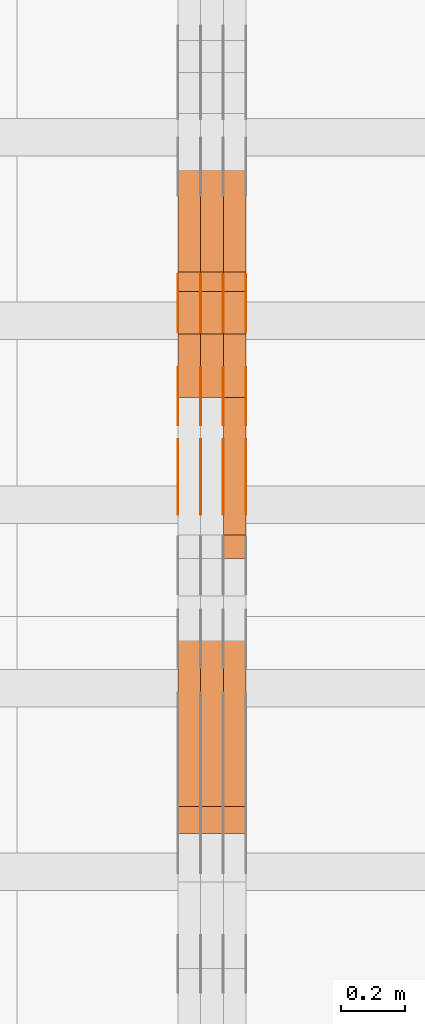
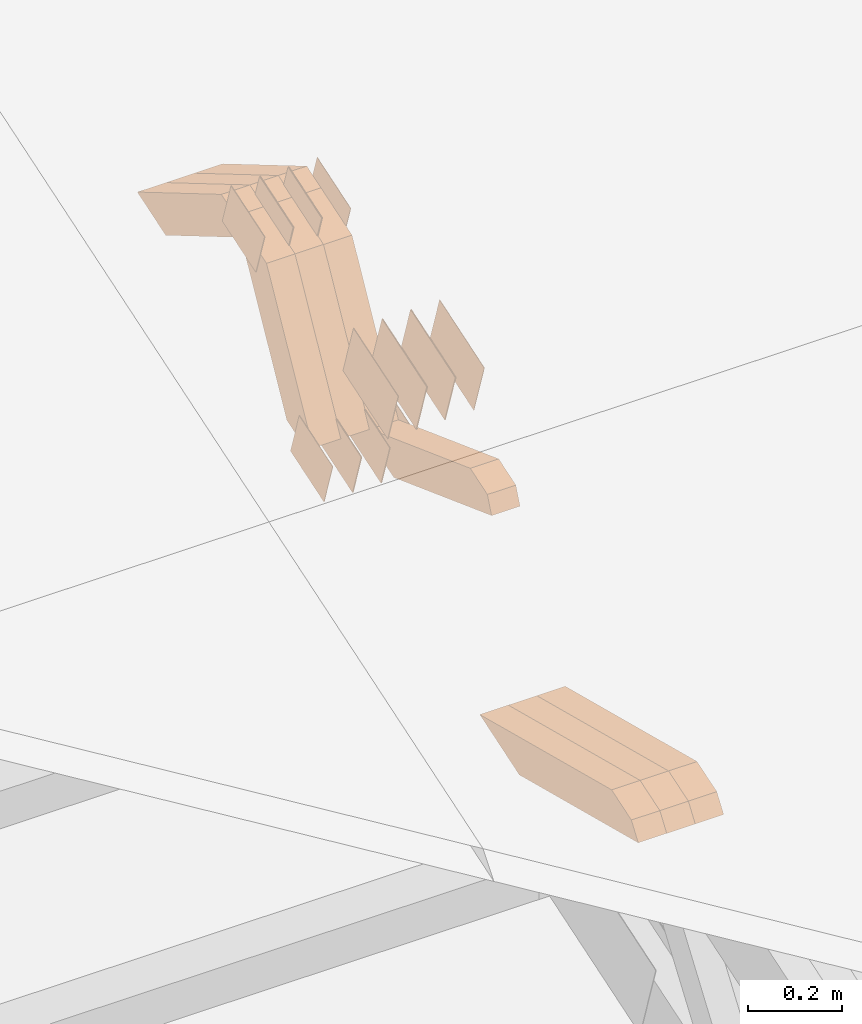
# One storey, part 140 of 385: 28 proxies.
"""IFC2X3 building model written with IfcOpenShell, lengths in millimetres."""

from ifc_helpers import new_model, entity, si_unit, converted_unit, derived_unit, direction, frame, origin, place, context, subcontext, project, spatial, polyline, outline, extrude, source, transform, mapped, material, type_object, type_shapes, element, save


model = new_model("IFC2X3")

# Units and contexts
model_context = context("Model", 3, precision=0.01, world=origin(), true_north=direction((6.12303176911189e-17, 1.0)))
body_context = subcontext(model_context, "Body", "Model", "MODEL_VIEW")
ifc_project = project(units=[si_unit("LENGTHUNIT", "METRE", prefix="MILLI"), si_unit("AREAUNIT", "SQUARE_METRE"), si_unit("VOLUMEUNIT", "CUBIC_METRE"), converted_unit("PLANEANGLEUNIT", "DEGREE", entity("IfcRatioMeasure", 0.0174532925199433), si_unit("PLANEANGLEUNIT", "RADIAN"), dimensions=[0, 0, 0, 0, 0, 0, 0]), si_unit("MASSUNIT", "GRAM", prefix="KILO"), derived_unit("MASSDENSITYUNIT", [(si_unit("MASSUNIT", "GRAM", prefix="KILO"), 1), (si_unit("LENGTHUNIT", "METRE"), -3)]), si_unit("TIMEUNIT", "SECOND"), si_unit("FREQUENCYUNIT", "HERTZ"), si_unit("THERMODYNAMICTEMPERATUREUNIT", "DEGREE_CELSIUS"), derived_unit("THERMALTRANSMITTANCEUNIT", [(si_unit("MASSUNIT", "GRAM", prefix="KILO"), 1), (si_unit("THERMODYNAMICTEMPERATUREUNIT", "KELVIN"), -1), (si_unit("TIMEUNIT", "SECOND"), -3)]), derived_unit("VOLUMETRICFLOWRATEUNIT", [(si_unit("LENGTHUNIT", "METRE"), 3), (si_unit("TIMEUNIT", "SECOND"), -1)]), si_unit("ELECTRICCURRENTUNIT", "AMPERE"), si_unit("ELECTRICVOLTAGEUNIT", "VOLT"), si_unit("POWERUNIT", "WATT"), si_unit("FORCEUNIT", "NEWTON", prefix="KILO"), si_unit("ILLUMINANCEUNIT", "LUX"), si_unit("LUMINOUSFLUXUNIT", "LUMEN"), si_unit("LUMINOUSINTENSITYUNIT", "CANDELA"), derived_unit("USERDEFINED", [(si_unit("MASSUNIT", "GRAM", prefix="KILO"), -1), (si_unit("LENGTHUNIT", "METRE"), -2), (si_unit("TIMEUNIT", "SECOND"), 3), (si_unit("LUMINOUSFLUXUNIT", "LUMEN"), 1)]), derived_unit("LINEARVELOCITYUNIT", [(si_unit("LENGTHUNIT", "METRE"), 1), (si_unit("TIMEUNIT", "SECOND"), -1)]), si_unit("PRESSUREUNIT", "PASCAL"), derived_unit("USERDEFINED", [(si_unit("LENGTHUNIT", "METRE"), -2), (si_unit("MASSUNIT", "GRAM", prefix="KILO"), 1), (si_unit("TIMEUNIT", "SECOND"), -2)])], contexts=[model_context])

# Site, building, storey
site_placement = place(None, origin())
site = spatial("IfcSite", under=ifc_project, at=site_placement, CompositionType="ELEMENT")
building_placement = place(site_placement, origin())
building = spatial("IfcBuilding", under=site, at=building_placement, CompositionType="ELEMENT")
storey_placement = place(building_placement, origin())
storey = spatial("IfcBuildingStorey", under=building, at=storey_placement, Name="Default", CompositionType="ELEMENT", Elevation=0.0)

# Proxies
ifc_material_1 = material(Name="IfcSurfaceStyle #383694")
building_element_proxy_type_1 = type_object("IfcBuildingElementProxyType", PredefinedType="NOTDEFINED", material=ifc_material_1)
shared_shape_1 = source(origin(), body_context, "Body", "SweptSolid", [
    extrude(outline(polyline([(-99.999644645517, -72.0000317581407), (100.000028485991, -72.0000317581407), (99.999644645517, 72.0000317581407), (-100.000028485991, 72.0000317581407), (-99.999644645517, -72.0000317581407)])), frame((100.000028485991, 72.0000317581407, 0.0), z_axis=(0.0, 0.0, 1.0), x_axis=(-1.0, 0.0, 0.0)), (0.0, 0.0, 1.0), 1.3),
])
type_shapes(building_element_proxy_type_1, [shared_shape_1])
proxy_1_placement = place(building_placement, frame((30386.3, 9012.6304394324, 2546.30522609783), z_axis=(-1.0, 0.0, 0.0), x_axis=(0.0, 0.951056516295154, 0.309016994374948)))
element("IfcBuildingElementProxy", 1, at=proxy_1_placement, inside=storey, type_object=building_element_proxy_type_1, material=ifc_material_1, context=body_context, shape_type="MappedRepresentation", body=[
    mapped(shared_shape_1, transform((0.0, 0.0, 0.0), scale=1.0)),
])
ifc_material_2 = material(Name="IfcSurfaceStyle #383637")
building_element_proxy_type_2 = type_object("IfcBuildingElementProxyType", PredefinedType="NOTDEFINED", material=ifc_material_2)
shared_shape_2 = source(origin(), body_context, "Body", "SweptSolid", [
    extrude(outline(polyline([(-99.999644645517, -72.0000317581407), (100.000028485991, -72.0000317581407), (99.999644645517, 72.0000317581407), (-100.000028485991, 72.0000317581407), (-99.999644645517, -72.0000317581407)])), frame((100.000028485991, 72.0000317581407, 0.0), z_axis=(0.0, 0.0, 1.0), x_axis=(-1.0, 0.0, 0.0)), (0.0, 0.0, 1.0), 1.3),
])
type_shapes(building_element_proxy_type_2, [shared_shape_2])
proxy_2_placement = place(building_placement, frame((30315.0, 9012.6304394324, 2546.30522609783), z_axis=(-1.0, 0.0, 0.0), x_axis=(0.0, 0.951056516295154, 0.309016994374948)))
element("IfcBuildingElementProxy", 2, at=proxy_2_placement, inside=storey, type_object=building_element_proxy_type_2, material=ifc_material_2, context=body_context, shape_type="MappedRepresentation", body=[
    mapped(shared_shape_2, transform((0.0, 0.0, 0.0), scale=1.0)),
])
ifc_material_3 = material(Name="IfcSurfaceStyle #383580")
building_element_proxy_type_3 = type_object("IfcBuildingElementProxyType", PredefinedType="NOTDEFINED", material=ifc_material_3)
shared_shape_3 = source(origin(), body_context, "Body", "SweptSolid", [
    extrude(outline(polyline([(-99.999644645517, -72.0000317581407), (100.000028485991, -72.0000317581407), (99.999644645517, 72.0000317581407), (-100.000028485991, 72.0000317581407), (-99.999644645517, -72.0000317581407)])), frame((100.000028485991, 72.0000317581407, 0.0), z_axis=(0.0, 0.0, 1.0), x_axis=(-1.0, 0.0, 0.0)), (0.0, 0.0, 1.0), 1.3),
])
type_shapes(building_element_proxy_type_3, [shared_shape_3])
proxy_3_placement = place(building_placement, frame((30316.3, 9012.6304394324, 2546.30522609783), z_axis=(-1.0, 0.0, 0.0), x_axis=(0.0, 0.951056516295154, 0.309016994374948)))
element("IfcBuildingElementProxy", 3, at=proxy_3_placement, inside=storey, type_object=building_element_proxy_type_3, material=ifc_material_3, context=body_context, shape_type="MappedRepresentation", body=[
    mapped(shared_shape_3, transform((0.0, 0.0, 0.0), scale=1.0)),
])
ifc_material_4 = material(Name="IfcSurfaceStyle #383523")
building_element_proxy_type_4 = type_object("IfcBuildingElementProxyType", PredefinedType="NOTDEFINED", material=ifc_material_4)
shared_shape_4 = source(origin(), body_context, "Body", "SweptSolid", [
    extrude(outline(polyline([(-99.999644645517, -72.0000317581407), (100.000028485991, -72.0000317581407), (99.999644645517, 72.0000317581407), (-100.000028485991, 72.0000317581407), (-99.999644645517, -72.0000317581407)])), frame((100.000028485991, 72.0000317581407, 0.0), z_axis=(0.0, 0.0, 1.0), x_axis=(-1.0, 0.0, 0.0)), (0.0, 0.0, 1.0), 1.29999999999998),
])
type_shapes(building_element_proxy_type_4, [shared_shape_4])
proxy_4_placement = place(building_placement, frame((30245.0, 9012.6304394324, 2546.30522609783), z_axis=(-1.0, 0.0, 0.0), x_axis=(0.0, 0.951056516295154, 0.309016994374948)))
element("IfcBuildingElementProxy", 4, at=proxy_4_placement, inside=storey, type_object=building_element_proxy_type_4, material=ifc_material_4, context=body_context, shape_type="MappedRepresentation", body=[
    mapped(shared_shape_4, transform((0.0, 0.0, 0.0), scale=1.0)),
])
ifc_material_5 = material(Name="IfcSurfaceStyle #383466")
building_element_proxy_type_5 = type_object("IfcBuildingElementProxyType", PredefinedType="NOTDEFINED", material=ifc_material_5)
shared_shape_5 = source(origin(), body_context, "Body", "SweptSolid", [
    extrude(outline(polyline([(-99.999644645517, -72.0000317581407), (100.000028485991, -72.0000317581407), (99.999644645517, 72.0000317581407), (-100.000028485991, 72.0000317581407), (-99.999644645517, -72.0000317581407)])), frame((100.000028485991, 72.0000317581407, 0.0), z_axis=(0.0, 0.0, 1.0), x_axis=(-1.0, 0.0, 0.0)), (0.0, 0.0, 1.0), 1.29999999999998),
])
type_shapes(building_element_proxy_type_5, [shared_shape_5])
proxy_5_placement = place(building_placement, frame((30246.3, 9012.6304394324, 2546.30522609783), z_axis=(-1.0, 0.0, 0.0), x_axis=(0.0, 0.951056516295154, 0.309016994374948)))
element("IfcBuildingElementProxy", 5, at=proxy_5_placement, inside=storey, type_object=building_element_proxy_type_5, material=ifc_material_5, context=body_context, shape_type="MappedRepresentation", body=[
    mapped(shared_shape_5, transform((0.0, 0.0, 0.0), scale=1.0)),
])
ifc_material_6 = material(Name="IfcSurfaceStyle #383409")
building_element_proxy_type_6 = type_object("IfcBuildingElementProxyType", PredefinedType="NOTDEFINED", material=ifc_material_6)
shared_shape_6 = source(origin(), body_context, "Body", "SweptSolid", [
    extrude(outline(polyline([(-99.999644645517, -72.0000317581407), (100.000028485991, -72.0000317581407), (99.999644645517, 72.0000317581407), (-100.000028485991, 72.0000317581407), (-99.999644645517, -72.0000317581407)])), frame((100.000028485991, 72.0000317581407, 0.0), z_axis=(0.0, 0.0, 1.0), x_axis=(-1.0, 0.0, 0.0)), (0.0, 0.0, 1.0), 1.29999999999999),
])
type_shapes(building_element_proxy_type_6, [shared_shape_6])
proxy_6_placement = place(building_placement, frame((30175.0, 9012.6304394324, 2546.30522609783), z_axis=(-1.0, 0.0, 0.0), x_axis=(0.0, 0.951056516295154, 0.309016994374948)))
element("IfcBuildingElementProxy", 6, at=proxy_6_placement, inside=storey, type_object=building_element_proxy_type_6, material=ifc_material_6, context=body_context, shape_type="MappedRepresentation", body=[
    mapped(shared_shape_6, transform((0.0, 0.0, 0.0), scale=1.0)),
])
ifc_material_7 = material(Name="IfcSurfaceStyle #383352")
building_element_proxy_type_7 = type_object("IfcBuildingElementProxyType", PredefinedType="NOTDEFINED", material=ifc_material_7)
shared_shape_7 = source(origin(), body_context, "Body", "SweptSolid", [
    extrude(outline(polyline([(-74.9998754286207, -60.0000016373506), (74.9998605591063, -60.0000016373506), (74.9998754286244, 60.0000016373506), (-74.9998605591099, 60.0000016373506), (-74.9998754286207, -60.0000016373506)])), frame((74.9998754286244, 60.0000016373506, 0.0), z_axis=(0.0, 0.0, 1.0), x_axis=(-1.0, 0.0, 0.0)), (0.0, 0.0, 1.0), 1.3),
])
type_shapes(building_element_proxy_type_7, [shared_shape_7])
proxy_7_placement = place(building_placement, frame((30386.3, 9580.89841427132, 2615.81135078741), z_axis=(-1.0, 0.0, 0.0), x_axis=(0.0, 0.951056516295154, 0.309016994374948)))
element("IfcBuildingElementProxy", 7, at=proxy_7_placement, inside=storey, type_object=building_element_proxy_type_7, material=ifc_material_7, context=body_context, shape_type="MappedRepresentation", body=[
    mapped(shared_shape_7, transform((0.0, 0.0, 0.0), scale=1.0)),
])
ifc_material_8 = material(Name="IfcSurfaceStyle #383295")
building_element_proxy_type_8 = type_object("IfcBuildingElementProxyType", PredefinedType="NOTDEFINED", material=ifc_material_8)
shared_shape_8 = source(origin(), body_context, "Body", "SweptSolid", [
    extrude(outline(polyline([(-74.9998754286207, -60.0000016373506), (74.9998605591063, -60.0000016373506), (74.9998754286244, 60.0000016373506), (-74.9998605591099, 60.0000016373506), (-74.9998754286207, -60.0000016373506)])), frame((74.9998754286244, 60.0000016373506, 0.0), z_axis=(0.0, 0.0, 1.0), x_axis=(-1.0, 0.0, 0.0)), (0.0, 0.0, 1.0), 1.3),
])
type_shapes(building_element_proxy_type_8, [shared_shape_8])
proxy_8_placement = place(building_placement, frame((30315.0, 9580.89841427132, 2615.81135078741), z_axis=(-1.0, 0.0, 0.0), x_axis=(0.0, 0.951056516295154, 0.309016994374948)))
element("IfcBuildingElementProxy", 8, at=proxy_8_placement, inside=storey, type_object=building_element_proxy_type_8, material=ifc_material_8, context=body_context, shape_type="MappedRepresentation", body=[
    mapped(shared_shape_8, transform((0.0, 0.0, 0.0), scale=1.0)),
])
ifc_material_9 = material(Name="IfcSurfaceStyle #383238")
building_element_proxy_type_9 = type_object("IfcBuildingElementProxyType", PredefinedType="NOTDEFINED", material=ifc_material_9)
shared_shape_9 = source(origin(), body_context, "Body", "SweptSolid", [
    extrude(outline(polyline([(-74.9998754286207, -60.0000016373506), (74.9998605591063, -60.0000016373506), (74.9998754286244, 60.0000016373506), (-74.9998605591099, 60.0000016373506), (-74.9998754286207, -60.0000016373506)])), frame((74.9998754286244, 60.0000016373506, 0.0), z_axis=(0.0, 0.0, 1.0), x_axis=(-1.0, 0.0, 0.0)), (0.0, 0.0, 1.0), 1.3),
])
type_shapes(building_element_proxy_type_9, [shared_shape_9])
proxy_9_placement = place(building_placement, frame((30316.3, 9580.89841427132, 2615.81135078741), z_axis=(-1.0, 0.0, 0.0), x_axis=(0.0, 0.951056516295154, 0.309016994374948)))
element("IfcBuildingElementProxy", 9, at=proxy_9_placement, inside=storey, type_object=building_element_proxy_type_9, material=ifc_material_9, context=body_context, shape_type="MappedRepresentation", body=[
    mapped(shared_shape_9, transform((0.0, 0.0, 0.0), scale=1.0)),
])
ifc_material_10 = material(Name="IfcSurfaceStyle #383181")
building_element_proxy_type_10 = type_object("IfcBuildingElementProxyType", PredefinedType="NOTDEFINED", material=ifc_material_10)
shared_shape_10 = source(origin(), body_context, "Body", "SweptSolid", [
    extrude(outline(polyline([(-74.9998754286207, -60.0000016373506), (74.9998605591063, -60.0000016373506), (74.9998754286244, 60.0000016373506), (-74.9998605591099, 60.0000016373506), (-74.9998754286207, -60.0000016373506)])), frame((74.9998754286244, 60.0000016373506, 0.0), z_axis=(0.0, 0.0, 1.0), x_axis=(-1.0, 0.0, 0.0)), (0.0, 0.0, 1.0), 1.29999999999999),
])
type_shapes(building_element_proxy_type_10, [shared_shape_10])
proxy_10_placement = place(building_placement, frame((30245.0, 9580.89841427132, 2615.81135078741), z_axis=(-1.0, 0.0, 0.0), x_axis=(0.0, 0.951056516295154, 0.309016994374948)))
element("IfcBuildingElementProxy", 10, at=proxy_10_placement, inside=storey, type_object=building_element_proxy_type_10, material=ifc_material_10, context=body_context, shape_type="MappedRepresentation", body=[
    mapped(shared_shape_10, transform((0.0, 0.0, 0.0), scale=1.0)),
])
ifc_material_11 = material(Name="IfcSurfaceStyle #383124")
building_element_proxy_type_11 = type_object("IfcBuildingElementProxyType", PredefinedType="NOTDEFINED", material=ifc_material_11)
shared_shape_11 = source(origin(), body_context, "Body", "SweptSolid", [
    extrude(outline(polyline([(-74.9998754286207, -60.0000016373506), (74.9998605591063, -60.0000016373506), (74.9998754286244, 60.0000016373506), (-74.9998605591099, 60.0000016373506), (-74.9998754286207, -60.0000016373506)])), frame((74.9998754286244, 60.0000016373506, 0.0), z_axis=(0.0, 0.0, 1.0), x_axis=(-1.0, 0.0, 0.0)), (0.0, 0.0, 1.0), 1.29999999999999),
])
type_shapes(building_element_proxy_type_11, [shared_shape_11])
proxy_11_placement = place(building_placement, frame((30246.3, 9580.89841427132, 2615.81135078741), z_axis=(-1.0, 0.0, 0.0), x_axis=(0.0, 0.951056516295154, 0.309016994374948)))
element("IfcBuildingElementProxy", 11, at=proxy_11_placement, inside=storey, type_object=building_element_proxy_type_11, material=ifc_material_11, context=body_context, shape_type="MappedRepresentation", body=[
    mapped(shared_shape_11, transform((0.0, 0.0, 0.0), scale=1.0)),
])
ifc_material_12 = material(Name="IfcSurfaceStyle #383067")
building_element_proxy_type_12 = type_object("IfcBuildingElementProxyType", PredefinedType="NOTDEFINED", material=ifc_material_12)
shared_shape_12 = source(origin(), body_context, "Body", "SweptSolid", [
    extrude(outline(polyline([(-74.9998754286207, -60.0000016373506), (74.9998605591063, -60.0000016373506), (74.9998754286244, 60.0000016373506), (-74.9998605591099, 60.0000016373506), (-74.9998754286207, -60.0000016373506)])), frame((74.9998754286244, 60.0000016373506, 0.0), z_axis=(0.0, 0.0, 1.0), x_axis=(-1.0, 0.0, 0.0)), (0.0, 0.0, 1.0), 1.29999999999999),
])
type_shapes(building_element_proxy_type_12, [shared_shape_12])
proxy_12_placement = place(building_placement, frame((30175.0, 9580.89841427132, 2615.81135078741), z_axis=(-1.0, 0.0, 0.0), x_axis=(0.0, 0.951056516295154, 0.309016994374948)))
element("IfcBuildingElementProxy", 12, at=proxy_12_placement, inside=storey, type_object=building_element_proxy_type_12, material=ifc_material_12, context=body_context, shape_type="MappedRepresentation", body=[
    mapped(shared_shape_12, transform((0.0, 0.0, 0.0), scale=1.0)),
])
ifc_material_13 = material(Name="IfcSurfaceStyle #382326")
building_element_proxy_type_13 = type_object("IfcBuildingElementProxyType", PredefinedType="NOTDEFINED", material=ifc_material_13)
shared_shape_13 = source(origin(), body_context, "Body", "SweptSolid", [
    extrude(outline(polyline([(-75.0008041947458, -59.9996998629349), (75.0007893252423, -59.9996998629349), (75.0008041947458, 59.9996998629349), (-75.0007893252423, 59.9996998629349), (-75.0008041947458, -59.9996998629349)])), frame((75.0008041947458, 60.0002282421692, 0.0), z_axis=(0.0, 0.0, 1.0), x_axis=(-1.0, 0.0, 0.0)), (0.0, 0.0, 1.0), 1.3),
])
type_shapes(building_element_proxy_type_13, [shared_shape_13])
proxy_13_placement = place(building_placement, frame((30386.3, 9291.048828125, 2194.94482421875), z_axis=(-1.0, 0.0, 0.0), x_axis=(0.0, 0.951056516295124, 0.309016994375039)))
element("IfcBuildingElementProxy", 13, at=proxy_13_placement, inside=storey, type_object=building_element_proxy_type_13, material=ifc_material_13, context=body_context, shape_type="MappedRepresentation", body=[
    mapped(shared_shape_13, transform((0.0, 0.0, 0.0), scale=1.0)),
])
ifc_material_14 = material(Name="IfcSurfaceStyle #382269")
building_element_proxy_type_14 = type_object("IfcBuildingElementProxyType", PredefinedType="NOTDEFINED", material=ifc_material_14)
shared_shape_14 = source(origin(), body_context, "Body", "SweptSolid", [
    extrude(outline(polyline([(-75.0008041947458, -59.9996998629349), (75.0007893252423, -59.9996998629349), (75.0008041947458, 59.9996998629349), (-75.0007893252423, 59.9996998629349), (-75.0008041947458, -59.9996998629349)])), frame((75.0008041947458, 60.0002282421692, 0.0), z_axis=(0.0, 0.0, 1.0), x_axis=(-1.0, 0.0, 0.0)), (0.0, 0.0, 1.0), 1.3),
])
type_shapes(building_element_proxy_type_14, [shared_shape_14])
proxy_14_placement = place(building_placement, frame((30315.0, 9291.048828125, 2194.94482421875), z_axis=(-1.0, 0.0, 0.0), x_axis=(0.0, 0.951056516295124, 0.309016994375039)))
element("IfcBuildingElementProxy", 14, at=proxy_14_placement, inside=storey, type_object=building_element_proxy_type_14, material=ifc_material_14, context=body_context, shape_type="MappedRepresentation", body=[
    mapped(shared_shape_14, transform((0.0, 0.0, 0.0), scale=1.0)),
])
ifc_material_15 = material(Name="IfcSurfaceStyle #382212")
building_element_proxy_type_15 = type_object("IfcBuildingElementProxyType", PredefinedType="NOTDEFINED", material=ifc_material_15)
shared_shape_15 = source(origin(), body_context, "Body", "SweptSolid", [
    extrude(outline(polyline([(-75.0008041947458, -59.9996998629349), (75.0007893252423, -59.9996998629349), (75.0008041947458, 59.9996998629349), (-75.0007893252423, 59.9996998629349), (-75.0008041947458, -59.9996998629349)])), frame((75.0008041947458, 60.0002282421692, 0.0), z_axis=(0.0, 0.0, 1.0), x_axis=(-1.0, 0.0, 0.0)), (0.0, 0.0, 1.0), 1.3),
])
type_shapes(building_element_proxy_type_15, [shared_shape_15])
proxy_15_placement = place(building_placement, frame((30316.3, 9291.048828125, 2194.94482421875), z_axis=(-1.0, 0.0, 0.0), x_axis=(0.0, 0.951056516295124, 0.309016994375039)))
element("IfcBuildingElementProxy", 15, at=proxy_15_placement, inside=storey, type_object=building_element_proxy_type_15, material=ifc_material_15, context=body_context, shape_type="MappedRepresentation", body=[
    mapped(shared_shape_15, transform((0.0, 0.0, 0.0), scale=1.0)),
])
ifc_material_16 = material(Name="IfcSurfaceStyle #382155")
building_element_proxy_type_16 = type_object("IfcBuildingElementProxyType", PredefinedType="NOTDEFINED", material=ifc_material_16)
shared_shape_16 = source(origin(), body_context, "Body", "SweptSolid", [
    extrude(outline(polyline([(-75.0008041947458, -59.9996998629349), (75.0007893252423, -59.9996998629349), (75.0008041947458, 59.9996998629349), (-75.0007893252423, 59.9996998629349), (-75.0008041947458, -59.9996998629349)])), frame((75.0008041947458, 60.0002282421692, 0.0), z_axis=(0.0, 0.0, 1.0), x_axis=(-1.0, 0.0, 0.0)), (0.0, 0.0, 1.0), 1.29999999999999),
])
type_shapes(building_element_proxy_type_16, [shared_shape_16])
proxy_16_placement = place(building_placement, frame((30245.0, 9291.048828125, 2194.94482421875), z_axis=(-1.0, 0.0, 0.0), x_axis=(0.0, 0.951056516295124, 0.309016994375039)))
element("IfcBuildingElementProxy", 16, at=proxy_16_placement, inside=storey, type_object=building_element_proxy_type_16, material=ifc_material_16, context=body_context, shape_type="MappedRepresentation", body=[
    mapped(shared_shape_16, transform((0.0, 0.0, 0.0), scale=1.0)),
])
ifc_material_17 = material(Name="IfcSurfaceStyle #382098")
building_element_proxy_type_17 = type_object("IfcBuildingElementProxyType", PredefinedType="NOTDEFINED", material=ifc_material_17)
shared_shape_17 = source(origin(), body_context, "Body", "SweptSolid", [
    extrude(outline(polyline([(-75.0008041947458, -59.9996998629349), (75.0007893252423, -59.9996998629349), (75.0008041947458, 59.9996998629349), (-75.0007893252423, 59.9996998629349), (-75.0008041947458, -59.9996998629349)])), frame((75.0008041947458, 60.0002282421692, 0.0), z_axis=(0.0, 0.0, 1.0), x_axis=(-1.0, 0.0, 0.0)), (0.0, 0.0, 1.0), 1.29999999999999),
])
type_shapes(building_element_proxy_type_17, [shared_shape_17])
proxy_17_placement = place(building_placement, frame((30246.3, 9291.048828125, 2194.94482421875), z_axis=(-1.0, 0.0, 0.0), x_axis=(0.0, 0.951056516295124, 0.309016994375039)))
element("IfcBuildingElementProxy", 17, at=proxy_17_placement, inside=storey, type_object=building_element_proxy_type_17, material=ifc_material_17, context=body_context, shape_type="MappedRepresentation", body=[
    mapped(shared_shape_17, transform((0.0, 0.0, 0.0), scale=1.0)),
])
ifc_material_18 = material(Name="IfcSurfaceStyle #382041")
building_element_proxy_type_18 = type_object("IfcBuildingElementProxyType", PredefinedType="NOTDEFINED", material=ifc_material_18)
shared_shape_18 = source(origin(), body_context, "Body", "SweptSolid", [
    extrude(outline(polyline([(-75.0008041947458, -59.9996998629349), (75.0007893252423, -59.9996998629349), (75.0008041947458, 59.9996998629349), (-75.0007893252423, 59.9996998629349), (-75.0008041947458, -59.9996998629349)])), frame((75.0008041947458, 60.0002282421692, 0.0), z_axis=(0.0, 0.0, 1.0), x_axis=(-1.0, 0.0, 0.0)), (0.0, 0.0, 1.0), 1.29999999999999),
])
type_shapes(building_element_proxy_type_18, [shared_shape_18])
proxy_18_placement = place(building_placement, frame((30175.0, 9291.048828125, 2194.94482421875), z_axis=(-1.0, 0.0, 0.0), x_axis=(0.0, 0.951056516295124, 0.309016994375039)))
element("IfcBuildingElementProxy", 18, at=proxy_18_placement, inside=storey, type_object=building_element_proxy_type_18, material=ifc_material_18, context=body_context, shape_type="MappedRepresentation", body=[
    mapped(shared_shape_18, transform((0.0, 0.0, 0.0), scale=1.0)),
])
ifc_material_19 = material(Name="IfcSurfaceStyle #359160")
building_element_proxy_type_19 = type_object("IfcBuildingElementProxyType", Name="T1-W43 359158", PredefinedType="NOTDEFINED", material=ifc_material_19)
shared_shape_19 = source(origin(), body_context, "Body", "SweptSolid", [
    extrude(outline(polyline([(-198.159905426436, -47.4999961988362), (173.155878681738, -47.4999961988362), (174.585865234707, -0.00038778214839239), (132.582704932703, 47.5001900899104), (-282.164543422712, 47.5001900899104), (-198.159905426436, -47.4999961988362)])), frame((174.585865234707, 47.5001900899104, 0.0), z_axis=(0.0, 0.0, 1.0), x_axis=(-1.0, 0.0, 0.0)), (0.0, 0.0, 1.0), 70.0),
])
type_shapes(building_element_proxy_type_19, [shared_shape_19])
proxy_19_placement = place(building_placement, frame((30385.0, 9730.71877771152, 2634.4881681647), z_axis=(-1.0, 0.0, 0.0), x_axis=(0.0, 0.861495156633645, -0.507765787639115)))
element("IfcBuildingElementProxy", 19, at=proxy_19_placement, inside=storey, type_object=building_element_proxy_type_19, material=ifc_material_19, Name="T1-W43", context=body_context, shape_type="MappedRepresentation", body=[
    mapped(shared_shape_19, transform((0.0, 0.0, 0.0), scale=1.0)),
])
ifc_material_20 = material(Name="IfcSurfaceStyle #359094")
building_element_proxy_type_20 = type_object("IfcBuildingElementProxyType", Name="T1-W43 359092", PredefinedType="NOTDEFINED", material=ifc_material_20)
shared_shape_20 = source(origin(), body_context, "Body", "SweptSolid", [
    extrude(outline(polyline([(-198.159905426436, -47.4999961988362), (173.155878681738, -47.4999961988362), (174.585865234707, -0.00038778214839239), (132.582704932703, 47.5001900899104), (-282.164543422712, 47.5001900899104), (-198.159905426436, -47.4999961988362)])), frame((174.585865234707, 47.5001900899104, 0.0), z_axis=(0.0, 0.0, 1.0), x_axis=(-1.0, 0.0, 0.0)), (0.0, 0.0, 1.0), 70.0),
])
type_shapes(building_element_proxy_type_20, [shared_shape_20])
proxy_20_placement = place(building_placement, frame((30315.0, 9730.71877771152, 2634.4881681647), z_axis=(-1.0, 0.0, 0.0), x_axis=(0.0, 0.861495156633645, -0.507765787639115)))
element("IfcBuildingElementProxy", 20, at=proxy_20_placement, inside=storey, type_object=building_element_proxy_type_20, material=ifc_material_20, Name="T1-W43", context=body_context, shape_type="MappedRepresentation", body=[
    mapped(shared_shape_20, transform((0.0, 0.0, 0.0), scale=1.0)),
])
ifc_material_21 = material(Name="IfcSurfaceStyle #359028")
building_element_proxy_type_21 = type_object("IfcBuildingElementProxyType", Name="T1-W43 359026", PredefinedType="NOTDEFINED", material=ifc_material_21)
shared_shape_21 = source(origin(), body_context, "Body", "SweptSolid", [
    extrude(outline(polyline([(-198.159905426436, -47.4999961988362), (173.155878681738, -47.4999961988362), (174.585865234707, -0.00038778214839239), (132.582704932703, 47.5001900899104), (-282.164543422712, 47.5001900899104), (-198.159905426436, -47.4999961988362)])), frame((174.585865234707, 47.5001900899104, 0.0), z_axis=(0.0, 0.0, 1.0), x_axis=(-1.0, 0.0, 0.0)), (0.0, 0.0, 1.0), 70.0),
])
type_shapes(building_element_proxy_type_21, [shared_shape_21])
proxy_21_placement = place(building_placement, frame((30245.0, 9730.71877771152, 2634.4881681647), z_axis=(-1.0, 0.0, 0.0), x_axis=(0.0, 0.861495156633645, -0.507765787639115)))
element("IfcBuildingElementProxy", 21, at=proxy_21_placement, inside=storey, type_object=building_element_proxy_type_21, material=ifc_material_21, Name="T1-W43", context=body_context, shape_type="MappedRepresentation", body=[
    mapped(shared_shape_21, transform((0.0, 0.0, 0.0), scale=1.0)),
])
ifc_material_22 = material(Name="IfcSurfaceStyle #358764")
building_element_proxy_type_22 = type_object("IfcBuildingElementProxyType", Name="T1-W33 358762", PredefinedType="NOTDEFINED", material=ifc_material_22)
shared_shape_22 = source(origin(), body_context, "Body", "SweptSolid", [
    extrude(outline(polyline([(-314.173070820175, -47.4997758466969), (139.635944117881, -47.4997758466969), (190.204920608233, 0.000348187720347082), (197.369205310989, 47.5001702328475), (-213.036999216928, 47.4990332728259), (-314.173070820175, -47.4997758466969)])), frame((197.369205310989, 47.5001702328475, 0.0), z_axis=(0.0, 0.0, 1.0), x_axis=(-1.0, 0.0, 0.0)), (0.0, 0.0, 1.0), 70.0),
])
type_shapes(building_element_proxy_type_22, [shared_shape_22])
proxy_22_placement = place(building_placement, frame((30385.0, 9376.96875, 2191.01977539063), z_axis=(-1.0, 0.0, 0.0), x_axis=(0.0, 0.481632628948835, 0.876373214293907)))
element("IfcBuildingElementProxy", 22, at=proxy_22_placement, inside=storey, type_object=building_element_proxy_type_22, material=ifc_material_22, Name="T1-W33", context=body_context, shape_type="MappedRepresentation", body=[
    mapped(shared_shape_22, transform((0.0, 0.0, 0.0), scale=1.0)),
])
ifc_material_23 = material(Name="IfcSurfaceStyle #358698")
building_element_proxy_type_23 = type_object("IfcBuildingElementProxyType", Name="T1-W33 358696", PredefinedType="NOTDEFINED", material=ifc_material_23)
shared_shape_23 = source(origin(), body_context, "Body", "SweptSolid", [
    extrude(outline(polyline([(-314.173070820175, -47.4997758466969), (139.635944117881, -47.4997758466969), (190.204920608233, 0.000348187720347082), (197.369205310989, 47.5001702328475), (-213.036999216928, 47.4990332728259), (-314.173070820175, -47.4997758466969)])), frame((197.369205310989, 47.5001702328475, 0.0), z_axis=(0.0, 0.0, 1.0), x_axis=(-1.0, 0.0, 0.0)), (0.0, 0.0, 1.0), 70.0),
])
type_shapes(building_element_proxy_type_23, [shared_shape_23])
proxy_23_placement = place(building_placement, frame((30315.0, 9376.96875, 2191.01977539063), z_axis=(-1.0, 0.0, 0.0), x_axis=(0.0, 0.481632628948835, 0.876373214293907)))
element("IfcBuildingElementProxy", 23, at=proxy_23_placement, inside=storey, type_object=building_element_proxy_type_23, material=ifc_material_23, Name="T1-W33", context=body_context, shape_type="MappedRepresentation", body=[
    mapped(shared_shape_23, transform((0.0, 0.0, 0.0), scale=1.0)),
])
ifc_material_24 = material(Name="IfcSurfaceStyle #358632")
building_element_proxy_type_24 = type_object("IfcBuildingElementProxyType", Name="T1-W33 358630", PredefinedType="NOTDEFINED", material=ifc_material_24)
shared_shape_24 = source(origin(), body_context, "Body", "SweptSolid", [
    extrude(outline(polyline([(-314.173070820175, -47.4997758466969), (139.635944117881, -47.4997758466969), (190.204920608233, 0.000348187720347082), (197.369205310989, 47.5001702328475), (-213.036999216928, 47.4990332728259), (-314.173070820175, -47.4997758466969)])), frame((197.369205310989, 47.5001702328475, 0.0), z_axis=(0.0, 0.0, 1.0), x_axis=(-1.0, 0.0, 0.0)), (0.0, 0.0, 1.0), 70.0),
])
type_shapes(building_element_proxy_type_24, [shared_shape_24])
proxy_24_placement = place(building_placement, frame((30245.0, 9376.96875, 2191.01977539063), z_axis=(-1.0, 0.0, 0.0), x_axis=(0.0, 0.481632628948835, 0.876373214293907)))
element("IfcBuildingElementProxy", 24, at=proxy_24_placement, inside=storey, type_object=building_element_proxy_type_24, material=ifc_material_24, Name="T1-W33", context=body_context, shape_type="MappedRepresentation", body=[
    mapped(shared_shape_24, transform((0.0, 0.0, 0.0), scale=1.0)),
])
ifc_material_25 = material(Name="IfcSurfaceStyle #358368")
building_element_proxy_type_25 = type_object("IfcBuildingElementProxyType", Name="T1-W25 358366", PredefinedType="NOTDEFINED", material=ifc_material_25)
shared_shape_25 = source(origin(), body_context, "Body", "SweptSolid", [
    extrude(outline(polyline([(-229.232772462784, -47.5001671709529), (214.075939394384, -47.5001671709529), (212.688957821661, -0.000141058964427199), (152.358910178478, 47.5002377004352), (-349.891034931738, 47.5002377004352), (-229.232772462784, -47.5001671709529)])), frame((214.075939394384, 47.5002377004352, 0.0), z_axis=(0.0, 0.0, 1.0), x_axis=(-1.0, 0.0, 0.0)), (0.0, 0.0, 1.0), 70.0),
])
type_shapes(building_element_proxy_type_25, [shared_shape_25])
proxy_25_placement = place(building_placement, frame((30385.0, 8892.81895960242, 2369.29665807578), z_axis=(-1.0, 0.0, 0.0), x_axis=(0.0, 0.938402514401222, -0.345544094097213)))
element("IfcBuildingElementProxy", 25, at=proxy_25_placement, inside=storey, type_object=building_element_proxy_type_25, material=ifc_material_25, Name="T1-W25", context=body_context, shape_type="MappedRepresentation", body=[
    mapped(shared_shape_25, transform((0.0, 0.0, 0.0), scale=1.0)),
])
ifc_material_26 = material(Name="IfcSurfaceStyle #357576")
building_element_proxy_type_26 = type_object("IfcBuildingElementProxyType", Name="T1-W11 357574", PredefinedType="NOTDEFINED", material=ifc_material_26)
shared_shape_26 = source(origin(), body_context, "Body", "SweptSolid", [
    extrude(outline(polyline([(-261.366417792209, -47.5000378467523), (260.949520182121, -47.5000378467523), (242.928845159301, -7.41559889341215e-06), (168.237407166939, 47.5000415545517), (-410.749354716152, 47.5000415545517), (-261.366417792209, -47.5000378467523)])), frame((260.949520182121, 47.5000415545517, 0.0), z_axis=(0.0, 0.0, 1.0), x_axis=(-1.0, 0.0, 0.0)), (0.0, 0.0, 1.0), 70.0),
])
type_shapes(building_element_proxy_type_26, [shared_shape_26])
proxy_26_placement = place(building_placement, frame((30385.0, 8017.44318793234, 2097.03832883996), z_axis=(-1.0, 0.0, 0.0), x_axis=(0.0, 0.968347201599873, -0.249607085543851)))
element("IfcBuildingElementProxy", 26, at=proxy_26_placement, inside=storey, type_object=building_element_proxy_type_26, material=ifc_material_26, Name="T1-W11", context=body_context, shape_type="MappedRepresentation", body=[
    mapped(shared_shape_26, transform((0.0, 0.0, 0.0), scale=1.0)),
])
ifc_material_27 = material(Name="IfcSurfaceStyle #357510")
building_element_proxy_type_27 = type_object("IfcBuildingElementProxyType", Name="T1-W11 357508", PredefinedType="NOTDEFINED", material=ifc_material_27)
shared_shape_27 = source(origin(), body_context, "Body", "SweptSolid", [
    extrude(outline(polyline([(-261.366417792209, -47.5000378467523), (260.949520182121, -47.5000378467523), (242.928845159301, -7.41559889341215e-06), (168.237407166939, 47.5000415545517), (-410.749354716152, 47.5000415545517), (-261.366417792209, -47.5000378467523)])), frame((260.949520182121, 47.5000415545517, 0.0), z_axis=(0.0, 0.0, 1.0), x_axis=(-1.0, 0.0, 0.0)), (0.0, 0.0, 1.0), 70.0),
])
type_shapes(building_element_proxy_type_27, [shared_shape_27])
proxy_27_placement = place(building_placement, frame((30315.0, 8017.44318793234, 2097.03832883996), z_axis=(-1.0, 0.0, 0.0), x_axis=(0.0, 0.968347201599873, -0.249607085543851)))
element("IfcBuildingElementProxy", 27, at=proxy_27_placement, inside=storey, type_object=building_element_proxy_type_27, material=ifc_material_27, Name="T1-W11", context=body_context, shape_type="MappedRepresentation", body=[
    mapped(shared_shape_27, transform((0.0, 0.0, 0.0), scale=1.0)),
])
ifc_material_28 = material(Name="IfcSurfaceStyle #357444")
building_element_proxy_type_28 = type_object("IfcBuildingElementProxyType", Name="T1-W11 357442", PredefinedType="NOTDEFINED", material=ifc_material_28)
shared_shape_28 = source(origin(), body_context, "Body", "SweptSolid", [
    extrude(outline(polyline([(-261.366417792209, -47.5000378467523), (260.949520182121, -47.5000378467523), (242.928845159301, -7.41559889341215e-06), (168.237407166939, 47.5000415545517), (-410.749354716152, 47.5000415545517), (-261.366417792209, -47.5000378467523)])), frame((260.949520182121, 47.5000415545517, 0.0), z_axis=(0.0, 0.0, 1.0), x_axis=(-1.0, 0.0, 0.0)), (0.0, 0.0, 1.0), 70.0),
])
type_shapes(building_element_proxy_type_28, [shared_shape_28])
proxy_28_placement = place(building_placement, frame((30245.0, 8017.44318793234, 2097.03832883996), z_axis=(-1.0, 0.0, 0.0), x_axis=(0.0, 0.968347201599873, -0.249607085543851)))
element("IfcBuildingElementProxy", 28, at=proxy_28_placement, inside=storey, type_object=building_element_proxy_type_28, material=ifc_material_28, Name="T1-W11", context=body_context, shape_type="MappedRepresentation", body=[
    mapped(shared_shape_28, transform((0.0, 0.0, 0.0), scale=1.0)),
])

save(model, "model.ifc")
